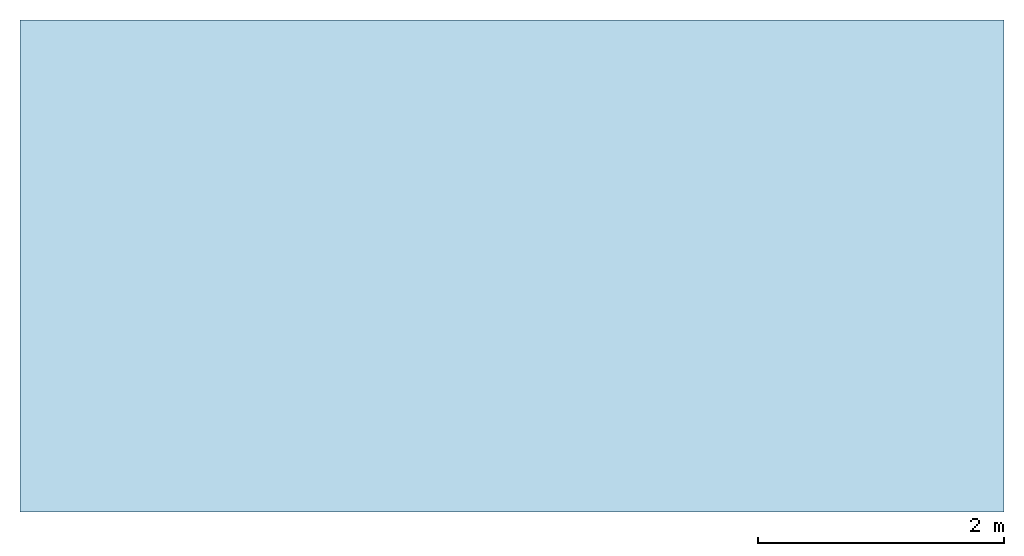
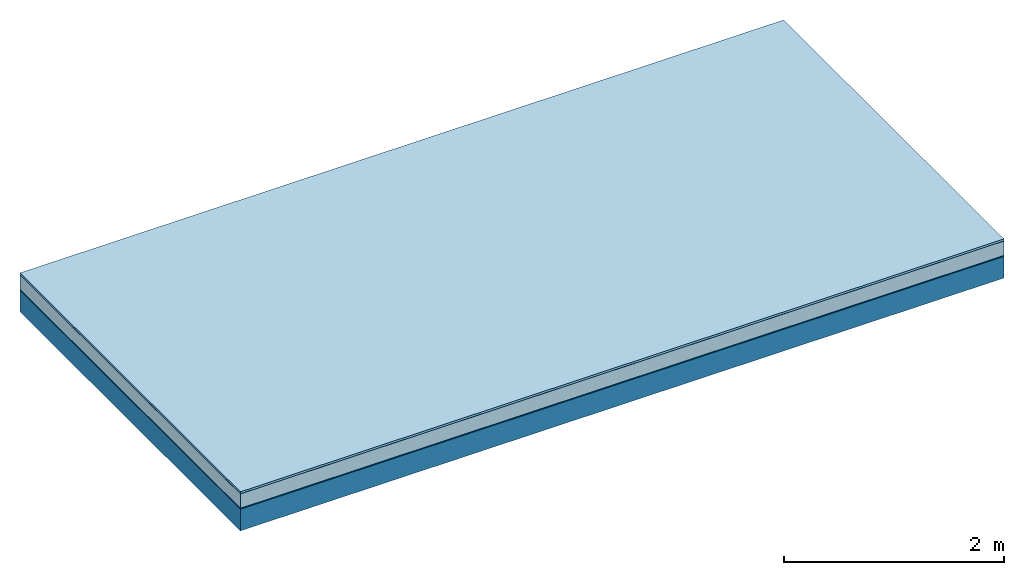
# One storey: 5 plates, 1 member, 1 element without a shape of its own.
"""IFC4 building model written with IfcOpenShell, lengths in metres."""

from ifc_helpers import new_model, si_unit, derived_unit, direction, frame, frame_2d, origin, origin_with_axes, place, context, project, spatial, rectangle, extrude, material, layer, layer_set, type_object, element, aggregate, save


model = new_model("IFC4")

# Units and contexts
plan_context = context("Plan", 3, precision=1e-05, world=origin(), true_north=direction((0.0, 1.0)))
model_context = context("Model", 3, precision=1e-05, world=origin(), true_north=direction((0.0, 1.0)))
ifc_project = project(units=[si_unit("LENGTHUNIT", "METRE"), derived_unit("SOUNDPRESSUREUNIT", [(si_unit("PRESSUREUNIT", "PASCAL", prefix="MICRO"), 0)]), si_unit("ENERGYUNIT", "JOULE", prefix="MEGA"), si_unit("MASSUNIT", "GRAM", prefix="KILO"), derived_unit("THERMALTRANSMITTANCEUNIT", [(si_unit("POWERUNIT", "WATT"), 1), (si_unit("AREAUNIT", "SQUARE_METRE"), -1), (si_unit("THERMODYNAMICTEMPERATUREUNIT", "KELVIN"), -1)]), derived_unit("AREADENSITYUNIT", [(si_unit("MASSUNIT", "GRAM", prefix="KILO"), 1), (si_unit("AREAUNIT", "SQUARE_METRE"), -1)]), derived_unit("USERDEFINED", [(si_unit("ENERGYUNIT", "JOULE", prefix="MEGA"), 1), (si_unit("AREAUNIT", "SQUARE_METRE"), -1)])], contexts=[plan_context, model_context])

# Site, building, storey
site = spatial("IfcSite", under=ifc_project)
building_placement = place(None, origin())
building = spatial("IfcBuilding", under=site, at=building_placement)
storey_placement = place(building_placement, origin())
storey = spatial("IfcBuildingStorey", under=building, at=storey_placement)

# Slab, member, plates
ifc_material_1 = material(Name="with tongue and groove", Category="07.009")
ifc_layer_1 = layer(ifc_material_1, 0.022, Name="Flooring")
ifc_material_2 = material(Category="09.006")
ifc_layer_2 = layer(ifc_material_2, 0.0005, Name="layer")
ifc_material_3 = material(Name="2x 60x80mm")
ifc_layer_3 = layer(ifc_material_3, 0.16, Name="On-material")
ifc_material_4 = material(Name="Wood fiber generic product", Category="10.009")
ifc_layer_4 = layer(ifc_material_4, 0.01, Name="Impact sound insulation")
ifc_material_5 = material(Name="protection", Category="09.007")
ifc_layer_5 = layer(ifc_material_5, 0.0005, Name="Sub-floor")
ifc_material_6 = material(Name="no composite action")
ifc_layer_6 = layer(ifc_material_6, 0.0, Name="Bond")
ifc_layer_7 = layer(None, 0.24, Name="Supporting structure")
ifc_layer_set = layer_set([ifc_layer_1, ifc_layer_2, ifc_layer_3, ifc_layer_4, ifc_layer_5, ifc_layer_6, ifc_layer_7])
slab_type = type_object("IfcSlabType", Name="A2030", PredefinedType="NOTDEFINED", material=ifc_layer_set)
slab_placement = place(None, frame((0.0, 0.0, 0.0), z_axis=(0.0, 0.0, -1.0), x_axis=(1.0, 0.0, 0.0)))
slab = element("IfcSlab", 1, at=slab_placement, inside=storey, type_object=slab_type, material=ifc_layer_set, Name="Slab #1")
ifc_material_7 = material(Name="Solid timber panel")
member_placement = place(slab_placement, origin())
member = element("IfcMember", 2, at=member_placement, material=ifc_material_7, Name="Supporting structure", context=plan_context, shape_type="SweptSolid", body=[
    extrude(rectangle(XDim=1.0, YDim=0.24, at=frame_2d((0.5, 0.12), x_axis=(1.0, 0.0))), frame((0.0, 4.0, 0.193), z_axis=(0.0, -1.0, 0.0), x_axis=(1.0, 0.0, 0.0)), (0.0, 0.0, 1.0), 4.0),
    extrude(rectangle(XDim=1.0, YDim=0.24, at=frame_2d((0.5, 0.12), x_axis=(1.0, 0.0))), frame((1.0, 4.0, 0.193), z_axis=(0.0, -1.0, 0.0), x_axis=(1.0, 0.0, 0.0)), (0.0, 0.0, 1.0), 4.0),
    extrude(rectangle(XDim=1.0, YDim=0.24, at=frame_2d((0.5, 0.12), x_axis=(1.0, 0.0))), frame((2.0, 4.0, 0.193), z_axis=(0.0, -1.0, 0.0), x_axis=(1.0, 0.0, 0.0)), (0.0, 0.0, 1.0), 4.0),
    extrude(rectangle(XDim=1.0, YDim=0.24, at=frame_2d((0.5, 0.12), x_axis=(1.0, 0.0))), frame((3.0, 4.0, 0.193), z_axis=(0.0, -1.0, 0.0), x_axis=(1.0, 0.0, 0.0)), (0.0, 0.0, 1.0), 4.0),
    extrude(rectangle(XDim=1.0, YDim=0.24, at=frame_2d((0.5, 0.12), x_axis=(1.0, 0.0))), frame((4.0, 4.0, 0.193), z_axis=(0.0, -1.0, 0.0), x_axis=(1.0, 0.0, 0.0)), (0.0, 0.0, 1.0), 4.0),
    extrude(rectangle(XDim=1.0, YDim=0.24, at=frame_2d((0.5, 0.12), x_axis=(1.0, 0.0))), frame((5.0, 4.0, 0.193), z_axis=(0.0, -1.0, 0.0), x_axis=(1.0, 0.0, 0.0)), (0.0, 0.0, 1.0), 4.0),
    extrude(rectangle(XDim=1.0, YDim=0.24, at=frame_2d((0.5, 0.12), x_axis=(1.0, 0.0))), frame((6.0, 4.0, 0.193), z_axis=(0.0, -1.0, 0.0), x_axis=(1.0, 0.0, 0.0)), (0.0, 0.0, 1.0), 4.0),
    extrude(rectangle(XDim=1.0, YDim=0.24, at=frame_2d((0.5, 0.12), x_axis=(1.0, 0.0))), frame((7.0, 4.0, 0.193), z_axis=(0.0, -1.0, 0.0), x_axis=(1.0, 0.0, 0.0)), (0.0, 0.0, 1.0), 4.0),
])
plate_1_placement = place(slab_placement, origin())
plate_1 = element("IfcPlate", 3, at=plate_1_placement, material=ifc_material_1, Name="Flooring", context=plan_context, shape_type="SweptSolid", body=[
    extrude(rectangle(XDim=8.0, YDim=4.0, at=frame_2d((4.0, 2.0), x_axis=(1.0, 0.0))), origin_with_axes(), (0.0, 0.0, 1.0), 0.022),
])
plate_2_placement = place(slab_placement, origin())
plate_2 = element("IfcPlate", 4, at=plate_2_placement, material=ifc_material_2, Name="layer", context=plan_context, shape_type="SweptSolid", body=[
    extrude(rectangle(XDim=8.0, YDim=4.0, at=frame_2d((4.0, 2.0), x_axis=(1.0, 0.0))), frame((0.0, 0.0, 0.022), z_axis=(0.0, 0.0, 1.0), x_axis=(1.0, 0.0, 0.0)), (0.0, 0.0, 1.0), 0.0005),
])
plate_3_placement = place(slab_placement, origin())
plate_3 = element("IfcPlate", 5, at=plate_3_placement, material=ifc_material_3, Name="On-material", context=plan_context, shape_type="SweptSolid", body=[
    extrude(rectangle(XDim=8.0, YDim=4.0, at=frame_2d((4.0, 2.0), x_axis=(1.0, 0.0))), frame((0.0, 0.0, 0.0225), z_axis=(0.0, 0.0, 1.0), x_axis=(1.0, 0.0, 0.0)), (0.0, 0.0, 1.0), 0.16),
])
plate_4_placement = place(slab_placement, origin())
plate_4 = element("IfcPlate", 6, at=plate_4_placement, material=ifc_material_4, Name="Impact sound insulation", context=plan_context, shape_type="SweptSolid", body=[
    extrude(rectangle(XDim=8.0, YDim=4.0, at=frame_2d((4.0, 2.0), x_axis=(1.0, 0.0))), frame((0.0, 0.0, 0.1825), z_axis=(0.0, 0.0, 1.0), x_axis=(1.0, 0.0, 0.0)), (0.0, 0.0, 1.0), 0.01),
])
plate_5_placement = place(slab_placement, origin())
plate_5 = element("IfcPlate", 7, at=plate_5_placement, material=ifc_material_5, Name="Sub-floor", context=plan_context, shape_type="SweptSolid", body=[
    extrude(rectangle(XDim=8.0, YDim=4.0, at=frame_2d((4.0, 2.0), x_axis=(1.0, 0.0))), frame((0.0, 0.0, 0.1925), z_axis=(0.0, 0.0, 1.0), x_axis=(1.0, 0.0, 0.0)), (0.0, 0.0, 1.0), 0.0005),
])
aggregate(slab, [plate_1, plate_2, plate_3, plate_4, plate_5, member])

save(model, "model.ifc")
